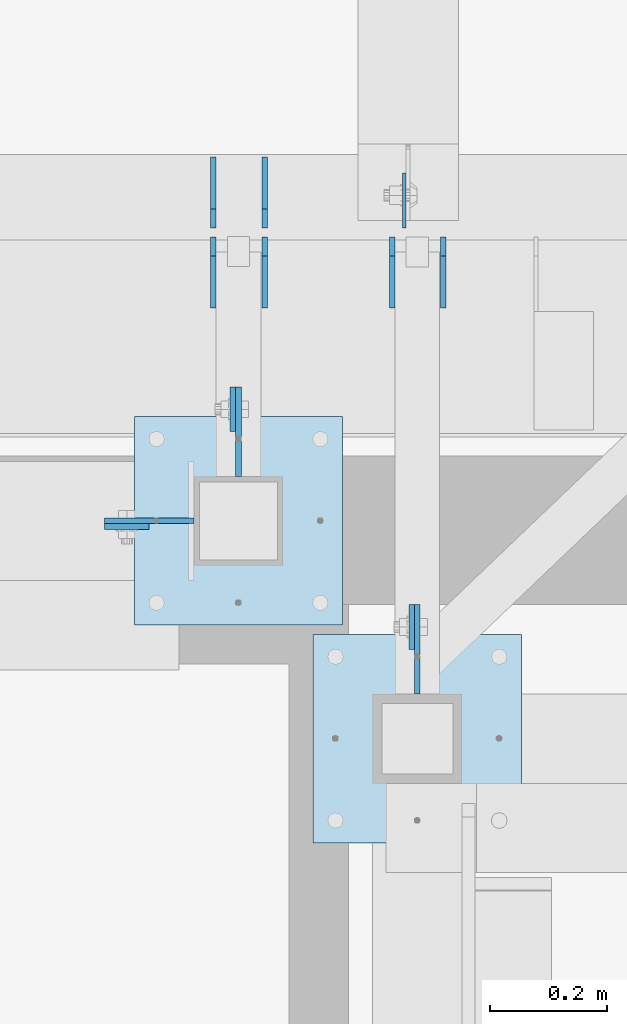
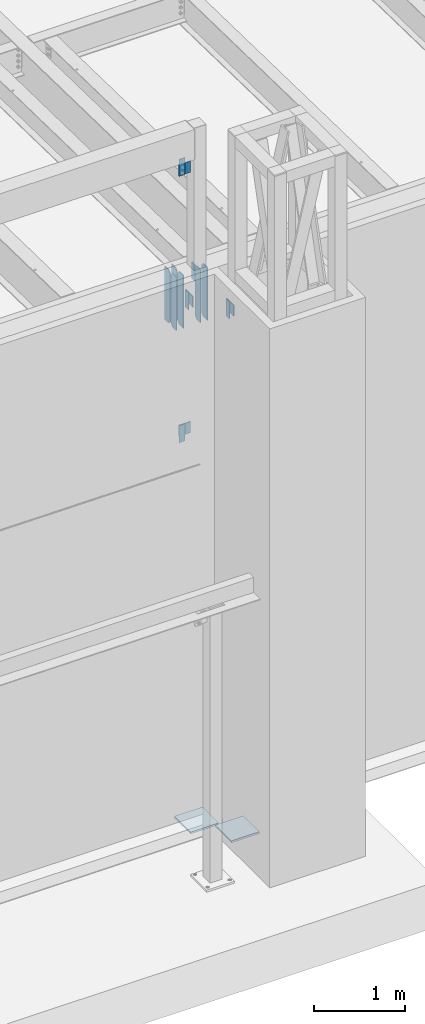
# One storey, part 1483 of 1763: 17 plates, 7 elements without a shape of their own.
"""IFC2X3 building model written with IfcOpenShell, lengths in millimetres."""

import ifcopenshell
import ifcopenshell.guid

model = None  # the IFC model being written
_history = None  # IfcOwnerHistory: only IFC2X3 demands one
_inside = {}  # id of a spatial element -> (the spatial element, [elements in it])
_under = {}  # id of a project, library or spatial element -> (it, [spatial elements below it])
_declared = {}  # id of a project -> (the project, [libraries it declares])
_typed = {}  # id of a type object -> (the type object, [elements of that type])
_made_of = {}  # id of a material, layer set ... -> (it, [elements and type objects made of it])


def new_model(schema):
    """Start an empty IFC model of exactly this schema.

    Asked for "IFC4X3", IfcOpenShell would pick the latest addendum, in which some entities
    have other attributes; the version numbers below select the first issue.
    IFC2X3 requires an IfcOwnerHistory on every rooted entity: one is made here for all.
    """
    global model, _history
    if schema == "IFC4X3":
        model = ifcopenshell.file(schema_version=(4, 3, 0, 0))
    else:
        model = ifcopenshell.file(schema=schema)
    _inside.clear()
    _under.clear()
    _declared.clear()
    _typed.clear()
    _made_of.clear()
    _history = None
    if model.schema == "IFC2X3":
        org = make("IfcOrganization", Name="unknown")
        user = make(
            "IfcPersonAndOrganization",
            ThePerson=make("IfcPerson", FamilyName="unknown"),
            TheOrganization=org,
        )
        app = make(
            "IfcApplication",
            ApplicationDeveloper=org,
            Version="unknown",
            ApplicationFullName="unknown",
            ApplicationIdentifier="unknown",
        )
        _history = make(
            "IfcOwnerHistory",
            OwningUser=user,
            OwningApplication=app,
            ChangeAction="ADDED",
            CreationDate=0,
        )
    return model


def make(cls, **values):
    """One entity of the class cls with the attributes given. An attribute that is None is left unset."""
    return model.create_entity(
        cls, **{name: value for name, value in values.items() if value is not None}
    )


def rooted(cls, **values):
    """An entity with a GlobalId (a new one), such as an element, a storey or a relation."""
    return make(cls, GlobalId=ifcopenshell.guid.new(), OwnerHistory=_history, **values)


def si_unit(unit_type, name, prefix=None):
    """IfcSIUnit, for example si_unit("LENGTHUNIT", "METRE", prefix="MILLI")."""
    return make("IfcSIUnit", UnitType=unit_type, Prefix=prefix, Name=name)


def assignment(units):
    """IfcUnitAssignment: the units of a project."""
    return None if units is None else make("IfcUnitAssignment", Units=units)


def point(xyz):
    """IfcCartesianPoint."""
    return None if xyz is None else make("IfcCartesianPoint", Coordinates=xyz)


def direction(xyz):
    """IfcDirection."""
    return None if xyz is None else make("IfcDirection", DirectionRatios=xyz)


def frame(location, z_axis=None, x_axis=None):
    """IfcAxis2Placement3D, a coordinate frame: its origin and axes. An axis left out is left unset."""
    return make(
        "IfcAxis2Placement3D",
        Location=point(location),
        Axis=direction(z_axis),
        RefDirection=direction(x_axis),
    )


def origin_with_axes():
    """The frame at (0, 0, 0) with the z axis (0, 0, 1) and the x axis (1, 0, 0) written out."""
    return frame((0.0, 0.0, 0.0), z_axis=(0.0, 0.0, 1.0), x_axis=(1.0, 0.0, 0.0))


def place(relative_to, where):
    """IfcLocalPlacement: puts the frame where relative to a parent placement (None: the world)."""
    return make(
        "IfcLocalPlacement", PlacementRelTo=relative_to, RelativePlacement=where
    )


def context(
    kind, dimensions, precision=None, world=None, true_north=None, identifier=None
):
    """IfcGeometricRepresentationContext, for example the 3D "Model" context."""
    return make(
        "IfcGeometricRepresentationContext",
        ContextIdentifier=identifier,
        ContextType=kind,
        CoordinateSpaceDimension=dimensions,
        Precision=precision,
        WorldCoordinateSystem=world,
        TrueNorth=true_north,
    )


def subcontext(parent, identifier, kind, view, scale=None):
    """IfcGeometricRepresentationSubContext, for example "Body" below "Model"."""
    return make(
        "IfcGeometricRepresentationSubContext",
        ContextIdentifier=identifier,
        ContextType=kind,
        ParentContext=parent,
        TargetScale=scale,
        TargetView=view,
    )


def project(units=None, contexts=None):
    """IfcProject with its units and contexts."""
    return rooted(
        "IfcProject",
        Name="project",
        RepresentationContexts=contexts,
        UnitsInContext=assignment(units),
    )


def spatial(cls, under=None, at=None, **own):
    """A site, building, storey or space (cls), placed at a placement, below another one or the project."""
    s = rooted(cls, ObjectPlacement=at, **own)
    if under is not None:
        _under.setdefault(under.id(), (under, []))[1].append(s)
    return s


def faces_of(points, faces, orient=None, outer=None):
    """IfcFace entities. A face is a list of loops; a loop is a list of indices into points, from 0.

    orient and outer hold one flag for each loop. By default every Orientation is true, the
    first loop of a face is its IfcFaceOuterBound and the others are IfcFaceBound.
    """
    made = []
    for i, loops in enumerate(faces):
        bounds = []
        for j, loop in enumerate(loops):
            is_outer = j == 0 if outer is None else outer[i][j]
            bounds.append(
                make(
                    "IfcFaceOuterBound" if is_outer else "IfcFaceBound",
                    Bound=make("IfcPolyLoop", Polygon=[points[k] for k in loop]),
                    Orientation=True if orient is None else orient[i][j],
                )
            )
        made.append(make("IfcFace", Bounds=bounds))
    return made


def faceted_brep(points, faces, orient=None, outer=None, voids=None):
    """IfcFacetedBrep: a solid bounded by flat faces; with voids (closed shells), ...WithVoids."""
    shared = [point(p) for p in points]
    hull = make("IfcClosedShell", CfsFaces=faces_of(shared, faces, orient, outer))
    if voids is None:
        return make("IfcFacetedBrep", Outer=hull)
    return make(
        "IfcFacetedBrepWithVoids",
        Outer=hull,
        Voids=[
            make(cls, CfsFaces=faces_of(shared, fs, o, b)) for cls, fs, o, b in voids
        ],
    )


def shape(context_of_items, identifier, shape_type, items):
    """IfcShapeRepresentation: the items that make up one representation, for example the "Body"."""
    return make(
        "IfcShapeRepresentation",
        ContextOfItems=context_of_items,
        RepresentationIdentifier=identifier,
        RepresentationType=shape_type,
        Items=items,
    )


def material(Name=None, Category=None):
    """IfcMaterial."""
    return make("IfcMaterial", Name=Name, Category=Category)


def made_of(thing, what):
    """Note that an element or type object is made of a material, layer set ...; save() writes the relation."""
    if what is not None:
        _made_of.setdefault(what.id(), (what, []))[1].append(thing)
    return thing


def type_object(cls, material=None, **own):
    """A type object (cls), such as IfcWallType, which elements share."""
    return made_of(rooted(cls, **own), material)


def element(
    cls,
    number,
    at=None,
    inside=None,
    cuts=None,
    type_object=None,
    material=None,
    context=None,
    identifier="Body",
    shape_type=None,
    held_by="IfcProductDefinitionShape",
    body=None,
    shapes=None,
    **own,
):
    """One element of the class cls, such as IfcWall. Its Tag is "e" and its number.

    at: its placement. inside: the storey or other place that contains it. cuts: it is an
    opening in that element (IfcRelVoidsElement). A single representation is given by context,
    identifier, shape_type and body (its items); several are given by shapes. held_by: the class
    of the entity that holds the representations. save() writes the other relations.
    """
    e = rooted(cls, Tag="e%d" % number, ObjectPlacement=at, **own)
    if body is not None:
        shapes = [shape(context, identifier, shape_type, body)]
    if shapes is not None:
        e.Representation = make(held_by, Representations=shapes)
    if inside is not None:
        _inside.setdefault(inside.id(), (inside, []))[1].append(e)
    if cuts is not None:
        rooted(
            "IfcRelVoidsElement", RelatingBuildingElement=cuts, RelatedOpeningElement=e
        )
    if type_object is not None:
        _typed.setdefault(type_object.id(), (type_object, []))[1].append(e)
    return made_of(e, material)


def aggregate(whole, parts):
    """IfcRelAggregates: a whole, such as a stair, and the parts it consists of."""
    return rooted("IfcRelAggregates", RelatingObject=whole, RelatedObjects=parts)


def save(model, path):
    """Write the relations noted so far, then the file.

    IfcRelAggregates (storeys below a building ...), IfcRelContainedInSpatialStructure (elements
    in a storey), IfcRelDefinesByType, IfcRelAssociatesMaterial and IfcRelDeclares: one each for
    every whole, place, type object, material and project.
    """
    for whole, parts in _under.values():
        aggregate(whole, parts)
    for where, things in _inside.values():
        rooted(
            "IfcRelContainedInSpatialStructure",
            RelatedElements=things,
            RelatingStructure=where,
        )
    for kind, things in _typed.values():
        rooted("IfcRelDefinesByType", RelatedObjects=things, RelatingType=kind)
    for what, things in _made_of.values():
        rooted("IfcRelAssociatesMaterial", RelatedObjects=things, RelatingMaterial=what)
    for by, libraries in _declared.values():
        rooted("IfcRelDeclares", RelatingContext=by, RelatedDefinitions=libraries)
    model.write(path)


model = new_model("IFC2X3")

# Units and contexts
model_context = context("Model", 3, precision=1e-05, world=origin_with_axes())
body_context = subcontext(model_context, "Body", "Model", "MODEL_VIEW")
ifc_project = project(units=[si_unit("LENGTHUNIT", "METRE", prefix="MILLI"), si_unit("AREAUNIT", "SQUARE_METRE"), si_unit("VOLUMEUNIT", "CUBIC_METRE"), si_unit("MASSUNIT", "GRAM", prefix="KILO"), si_unit("TIMEUNIT", "SECOND"), si_unit("PLANEANGLEUNIT", "RADIAN"), si_unit("SOLIDANGLEUNIT", "STERADIAN"), si_unit("THERMODYNAMICTEMPERATUREUNIT", "DEGREE_CELSIUS"), si_unit("LUMINOUSINTENSITYUNIT", "LUMEN")], contexts=[model_context])

# Site, building, storey
site_placement = place(None, origin_with_axes())
site = spatial("IfcSite", under=ifc_project, at=site_placement, CompositionType="ELEMENT")
building_placement = place(site_placement, origin_with_axes())
building = spatial("IfcBuilding", under=site, at=building_placement, Name="Undefined", CompositionType="ELEMENT")
storey_placement = place(building_placement, origin_with_axes())
storey = spatial("IfcBuildingStorey", under=building, at=storey_placement, Name="Undefined", CompositionType="ELEMENT", Elevation=0.0)

# Assembly, plate
assembly_1_placement = place(storey_placement, origin_with_axes())
assembly_1 = element("IfcElementAssembly", 1, at=assembly_1_placement, inside=storey, Name="BEAM", AssemblyPlace="NOTDEFINED", PredefinedType="RIGID_FRAME")
ifc_material = material(Name="STEEL/A36")
plate_type_1 = type_object("IfcPlateType", PredefinedType="NOTDEFINED")
plate_1_placement = place(assembly_1_placement, frame((-42097.1806100001, -14217.6514913088, 14058.9), z_axis=(0.0, 0.0, -1.0), x_axis=(-1.0, 0.0, 0.0)))
plate_1 = element("IfcPlate", 2, at=plate_1_placement, type_object=plate_type_1, material=ifc_material, Name="PLATE", context=body_context, shape_type="Brep", body=[
    faceted_brep([(0.0, -4.76249999999982, 0.0), (-2.83762346953154e-10, -4.7624999996915, 228.600006103516), (-2.83762346953154e-10, 4.76250000028813, 228.600006103517), (0.0, 4.76249999999982, 0.0), (76.1999969480166, -4.76249999961874, 228.600006103516), (76.1999969480166, 4.76250000036089, 228.600006103517), (76.1999969482931, -4.76249999991705, 0.0), (76.1999969482931, 4.76250000006257, 1.81898940354586e-12)], [[[0, 1, 2, 3]], [[1, 4, 5, 2]], [[4, 6, 7, 5]], [[6, 0, 3, 7]], [[5, 7, 3, 2]], [[6, 4, 1, 0]]]),
])
aggregate(assembly_1, [plate_1])

assembly_2_placement = place(storey_placement, origin_with_axes())
assembly_2 = element("IfcElementAssembly", 3, at=assembly_2_placement, inside=storey, Name="BEAM", AssemblyPlace="NOTDEFINED", PredefinedType="RIGID_FRAME")
plate_2_placement = place(assembly_2_placement, frame((-41954.3050625592, -14055.7264648314, 11858.625), z_axis=(0.0, 0.0, 1.0), x_axis=(0.0, 1.0, 0.0)))
plate_2 = element("IfcPlate", 4, at=plate_2_placement, type_object=plate_type_1, material=ifc_material, Name="PLATE", context=body_context, shape_type="Brep", body=[
    faceted_brep([(0.0, -4.76249999999982, 0.0), (-2.83762346953154e-10, -4.7624999996915, 228.600006103516), (-2.83762346953154e-10, 4.76250000028813, 228.600006103517), (0.0, 4.76249999999982, 0.0), (76.1999969480166, -4.76249999961874, 228.600006103516), (76.1999969480166, 4.76250000036089, 228.600006103517), (76.1999969482931, -4.76249999991705, 0.0), (76.1999969482931, 4.76250000006257, 1.81898940354586e-12)], [[[0, 1, 2, 3]], [[1, 4, 5, 2]], [[4, 6, 7, 5]], [[6, 0, 3, 7]], [[5, 7, 3, 2]], [[6, 4, 1, 0]]]),
])
aggregate(assembly_2, [plate_2])

assembly_3_placement = place(storey_placement, origin_with_axes())
assembly_3 = element("IfcElementAssembly", 5, at=assembly_3_placement, inside=storey, Name="BEAM", AssemblyPlace="NOTDEFINED", PredefinedType="RIGID_FRAME")
plate_3_placement = place(assembly_3_placement, frame((-42097.1802681081, -14217.6514930879, 10248.9), z_axis=(0.0, 0.0, 1.0), x_axis=(-1.0, 0.0, 0.0)))
plate_3 = element("IfcPlate", 6, at=plate_3_placement, type_object=plate_type_1, material=ifc_material, Name="PLATE", context=body_context, shape_type="Brep", body=[
    faceted_brep([(0.0, -4.76249999999982, 0.0), (-2.83762346953154e-10, -4.7624999996915, 228.600006103516), (-2.83762346953154e-10, 4.76250000028813, 228.600006103517), (0.0, 4.76249999999982, 0.0), (76.1999969480166, -4.76249999961874, 228.600006103516), (76.1999969480166, 4.76250000036089, 228.600006103517), (76.1999969482931, -4.76249999991705, 0.0), (76.1999969482931, 4.76250000006257, 1.81898940354586e-12)], [[[0, 1, 2, 3]], [[1, 4, 5, 2]], [[4, 6, 7, 5]], [[6, 0, 3, 7]], [[5, 7, 3, 2]], [[6, 4, 1, 0]]]),
])
aggregate(assembly_3, [plate_3])

assembly_4_placement = place(storey_placement, origin_with_axes())
assembly_4 = element("IfcElementAssembly", 7, at=assembly_4_placement, inside=storey, Name="BEAM", AssemblyPlace="NOTDEFINED", PredefinedType="RIGID_FRAME")
plate_4_placement = place(assembly_4_placement, frame((-41649.0884976177, -14427.1305908079, 11858.625), z_axis=(0.0, 0.0, 1.0), x_axis=(0.0, 1.0, 0.0)))
plate_4 = element("IfcPlate", 8, at=plate_4_placement, type_object=plate_type_1, material=ifc_material, Name="PLATE", context=body_context, shape_type="Brep", body=[
    faceted_brep([(0.0, -4.76249999999982, 0.0), (-2.83762346953154e-10, -4.7624999996915, 228.600006103516), (-2.83762346953154e-10, 4.76250000028813, 228.600006103517), (0.0, 4.76249999999982, 0.0), (76.1999969480166, -4.76249999961874, 228.600006103516), (76.1999969480166, 4.76250000036089, 228.600006103517), (76.1999969482931, -4.76249999991705, 0.0), (76.1999969482931, 4.76250000006257, 1.81898940354586e-12)], [[[0, 1, 2, 3]], [[1, 4, 5, 2]], [[4, 6, 7, 5]], [[6, 0, 3, 7]], [[5, 7, 3, 2]], [[6, 4, 1, 0]]]),
])
aggregate(assembly_4, [plate_4])

# Assembly, plates
assembly_5_placement = place(storey_placement, origin_with_axes())
assembly_5 = element("IfcElementAssembly", 9, at=assembly_5_placement, inside=storey, Name="BEAM", AssemblyPlace="NOTDEFINED", PredefinedType="RIGID_FRAME")
plate_type_2 = type_object("IfcPlateType", PredefinedType="NOTDEFINED")
plate_5_placement = place(assembly_5_placement, frame((-41900.330256172, -13844.5873186171, 11463.3375), z_axis=(0.0, 0.0, 1.0), x_axis=(0.0, 1.0, 0.0)))
plate_5 = element("IfcPlate", 10, at=plate_5_placement, type_object=plate_type_2, material=ifc_material, Name="PLATE", context=body_context, shape_type="Brep", body=[
    faceted_brep([(0.0, -4.76249999999982, 0.0), (0.0, -4.76249999999709, 714.375), (0.0, 4.76249999999709, 714.375), (0.0, 4.76249999999982, 0.0), (88.9000015258789, -4.76249999999709, 714.375), (88.9000015258789, 4.76249999999709, 714.375), (120.650001525879, -4.76249999999709, 682.625), (120.650001525879, 4.76249999999709, 682.625), (120.650001525879, -4.76249999999709, 31.75), (120.650001525879, 4.76249999999709, 31.75), (88.9000015258789, -4.76249999999709, 0.0), (88.9000015258789, 4.76249999999709, 0.0)], [[[0, 1, 2, 3]], [[1, 4, 5, 2]], [[4, 6, 7, 5]], [[6, 8, 9, 7]], [[8, 10, 11, 9]], [[10, 0, 3, 11]], [[5, 7, 9, 11, 3, 2]], [[10, 8, 6, 4, 1, 0]]]),
])
plate_6_placement = place(assembly_5_placement, frame((-41900.330256172, -13708.0623186171, 11463.3375), z_axis=(0.0, 0.0, 1.0), x_axis=(0.0, 1.0, 0.0)))
plate_6 = element("IfcPlate", 11, at=plate_6_placement, type_object=plate_type_2, material=ifc_material, Name="PLATE", context=body_context, shape_type="Brep", body=[
    faceted_brep([(0.0, -4.76250000000073, 31.75), (0.0, -4.76249999999709, 682.625), (0.0, 4.76249999999709, 682.625), (0.0, 4.76250000000073, 31.75), (31.75, -4.76249999999709, 714.375), (31.75, 4.76249999999709, 714.375), (120.650001525879, -4.76249999999709, 714.375), (120.650001525879, 4.76249999999709, 714.375), (120.650001525879, -4.76249999999709, 0.0), (120.650001525879, 4.76249999999709, 0.0), (31.75, -4.76250000000073, 0.0), (31.75, 4.76250000000073, 0.0)], [[[0, 1, 2, 3]], [[1, 4, 5, 2]], [[4, 6, 7, 5]], [[6, 8, 9, 7]], [[8, 10, 11, 9]], [[10, 0, 3, 11]], [[5, 7, 9, 11, 3, 2]], [[10, 8, 6, 4, 1, 0]]]),
])
plate_7_placement = place(assembly_5_placement, frame((-41987.642756172, -13844.5873186171, 11463.3375), z_axis=(0.0, 0.0, 1.0), x_axis=(0.0, 1.0, 0.0)))
plate_7 = element("IfcPlate", 12, at=plate_7_placement, type_object=plate_type_2, material=ifc_material, Name="PLATE", context=body_context, shape_type="Brep", body=[
    faceted_brep([(0.0, -4.76249999999982, 0.0), (0.0, -4.76249999999709, 714.375), (0.0, 4.76249999999709, 714.375), (0.0, 4.76249999999982, 0.0), (88.9000015258789, -4.76249999999709, 714.375), (88.9000015258789, 4.76249999999709, 714.375), (120.650001525879, -4.76249999999709, 682.625), (120.650001525879, 4.76249999999709, 682.625), (120.650001525879, -4.76249999999709, 31.75), (120.650001525879, 4.76249999999709, 31.75), (88.9000015258789, -4.76249999999709, 0.0), (88.9000015258789, 4.76249999999709, 0.0)], [[[0, 1, 2, 3]], [[1, 4, 5, 2]], [[4, 6, 7, 5]], [[6, 8, 9, 7]], [[8, 10, 11, 9]], [[10, 0, 3, 11]], [[5, 7, 9, 11, 3, 2]], [[10, 8, 6, 4, 1, 0]]]),
])
plate_8_placement = place(assembly_5_placement, frame((-41987.642756172, -13708.0623186171, 11463.3375), z_axis=(0.0, 0.0, 1.0), x_axis=(0.0, 1.0, 0.0)))
plate_8 = element("IfcPlate", 13, at=plate_8_placement, type_object=plate_type_2, material=ifc_material, Name="PLATE", context=body_context, shape_type="Brep", body=[
    faceted_brep([(0.0, -4.76250000000073, 31.75), (0.0, -4.76249999999709, 682.625), (0.0, 4.76249999999709, 682.625), (0.0, 4.76250000000073, 31.75), (31.75, -4.76249999999709, 714.375), (31.75, 4.76249999999709, 714.375), (120.650001525879, -4.76249999999709, 714.375), (120.650001525879, 4.76249999999709, 714.375), (120.650001525879, -4.76249999999709, 0.0), (120.650001525879, 4.76249999999709, 0.0), (31.75, -4.76250000000073, 0.0), (31.75, 4.76250000000073, 0.0)], [[[0, 1, 2, 3]], [[1, 4, 5, 2]], [[4, 6, 7, 5]], [[6, 8, 9, 7]], [[8, 10, 11, 9]], [[10, 0, 3, 11]], [[5, 7, 9, 11, 3, 2]], [[10, 8, 6, 4, 1, 0]]]),
])
plate_9_placement = place(assembly_5_placement, frame((-41595.1134959181, -13844.5873186171, 11463.3375), z_axis=(0.0, 0.0, 1.0), x_axis=(0.0, 1.0, 0.0)))
plate_9 = element("IfcPlate", 14, at=plate_9_placement, type_object=plate_type_2, material=ifc_material, Name="PLATE", context=body_context, shape_type="Brep", body=[
    faceted_brep([(0.0, -4.76249999999982, 0.0), (0.0, -4.76249999999709, 714.375), (0.0, 4.76249999999709, 714.375), (0.0, 4.76249999999982, 0.0), (88.9000015258789, -4.76249999999709, 714.375), (88.9000015258789, 4.76249999999709, 714.375), (120.650001525879, -4.76249999999709, 682.625), (120.650001525879, 4.76249999999709, 682.625), (120.650001525879, -4.76249999999709, 31.75), (120.650001525879, 4.76249999999709, 31.75), (88.9000015258789, -4.76249999999709, 0.0), (88.9000015258789, 4.76249999999709, 0.0)], [[[0, 1, 2, 3]], [[1, 4, 5, 2]], [[4, 6, 7, 5]], [[6, 8, 9, 7]], [[8, 10, 11, 9]], [[10, 0, 3, 11]], [[5, 7, 9, 11, 3, 2]], [[10, 8, 6, 4, 1, 0]]]),
])
plate_10_placement = place(assembly_5_placement, frame((-41682.4259959181, -13844.5873186171, 11463.3375), z_axis=(0.0, 0.0, 1.0), x_axis=(0.0, 1.0, 0.0)))
plate_10 = element("IfcPlate", 15, at=plate_10_placement, type_object=plate_type_2, material=ifc_material, Name="PLATE", context=body_context, shape_type="Brep", body=[
    faceted_brep([(0.0, -4.76249999999982, 0.0), (0.0, -4.76249999999709, 714.375), (0.0, 4.76249999999709, 714.375), (0.0, 4.76249999999982, 0.0), (88.9000015258789, -4.76249999999709, 714.375), (88.9000015258789, 4.76249999999709, 714.375), (120.650001525879, -4.76249999999709, 682.625), (120.650001525879, 4.76249999999709, 682.625), (120.650001525879, -4.76249999999709, 31.75), (120.650001525879, 4.76249999999709, 31.75), (88.9000015258789, -4.76249999999709, 0.0), (88.9000015258789, 4.76249999999709, 0.0)], [[[0, 1, 2, 3]], [[1, 4, 5, 2]], [[4, 6, 7, 5]], [[6, 8, 9, 7]], [[8, 10, 11, 9]], [[10, 0, 3, 11]], [[5, 7, 9, 11, 3, 2]], [[10, 8, 6, 4, 1, 0]]]),
])

assembly_6_placement = place(storey_placement, origin_with_axes())
assembly_6 = element("IfcElementAssembly", 16, at=assembly_6_placement, inside=storey, Name="COLUMN", AssemblyPlace="NOTDEFINED", PredefinedType="RIGID_FRAME")
plate_type_3 = type_object("IfcPlateType", PredefinedType="NOTDEFINED")
plate_11_placement = place(assembly_6_placement, frame((-42173.3806069008, -14208.126492046, 13830.2999938965), z_axis=(0.0, 0.0, 1.0), x_axis=(1.0, 0.0, 0.0)))
plate_11 = element("IfcPlate", 17, at=plate_11_placement, type_object=plate_type_3, material=ifc_material, Name="PLATE", context=body_context, shape_type="Brep", body=[
    faceted_brep([(0.0, -4.76249999999982, 0.0), (-3.05175672110636e-06, -4.7625000002663, 152.399993896484), (-3.05175490211695e-06, 4.76249999972788, 152.399993896484), (0.0, 4.76249999999982, 0.0), (152.400009155272, -4.76249999975698, 152.399993896484), (152.400009155273, 4.76250000024447, 152.399993896484), (152.400009155272, -4.76249999948777, 5.45696821063757e-12), (152.400009155273, 4.76250000051368, 3.63797880709171e-12)], [[[0, 1, 2, 3]], [[1, 4, 5, 2]], [[4, 6, 7, 5]], [[6, 0, 3, 7]], [[5, 7, 3, 2]], [[6, 4, 1, 0]]]),
])
plate_12_placement = place(assembly_6_placement, frame((-41944.7800640592, -13979.5264678355, 12087.2250061035), z_axis=(0.0, 0.0, -1.0), x_axis=(0.0, -1.0, 0.0)))
plate_12 = element("IfcPlate", 18, at=plate_12_placement, type_object=plate_type_3, material=ifc_material, Name="PLATE", context=body_context, shape_type="Brep", body=[
    faceted_brep([(0.0, -4.76249999999982, 0.0), (-3.05175672110636e-06, -4.7625000002663, 152.399993896484), (-3.05175490211695e-06, 4.76249999972788, 152.399993896484), (0.0, 4.76249999999982, 0.0), (152.400009155272, -4.76249999975698, 152.399993896484), (152.400009155273, 4.76250000024447, 152.399993896484), (152.400009155272, -4.76249999948777, 5.45696821063757e-12), (152.400009155273, 4.76250000051368, 3.63797880709171e-12)], [[[0, 1, 2, 3]], [[1, 4, 5, 2]], [[4, 6, 7, 5]], [[6, 0, 3, 7]], [[5, 7, 3, 2]], [[6, 4, 1, 0]]]),
])
plate_13_placement = place(assembly_6_placement, frame((-42173.3802651039, -14208.1264945876, 10477.5000061035), z_axis=(0.0, 0.0, -1.0), x_axis=(1.0, 0.0, 0.0)))
plate_13 = element("IfcPlate", 19, at=plate_13_placement, type_object=plate_type_3, material=ifc_material, Name="PLATE", context=body_context, shape_type="Brep", body=[
    faceted_brep([(0.0, -4.76249999999982, 0.0), (-3.05175672110636e-06, -4.7625000002663, 152.399993896484), (-3.05175490211695e-06, 4.76249999972788, 152.399993896484), (0.0, 4.76249999999982, 0.0), (152.400009155272, -4.76249999975698, 152.399993896484), (152.400009155273, 4.76250000024447, 152.399993896484), (152.400009155272, -4.76249999948777, 5.45696821063757e-12), (152.400009155273, 4.76250000051368, 3.63797880709171e-12)], [[[0, 1, 2, 3]], [[1, 4, 5, 2]], [[4, 6, 7, 5]], [[6, 0, 3, 7]], [[5, 7, 3, 2]], [[6, 4, 1, 0]]]),
])

# Assembly, plate
assembly_7_placement = place(storey_placement, origin_with_axes())
assembly_7 = element("IfcElementAssembly", 20, at=assembly_7_placement, inside=storey, Name="FRAME", AssemblyPlace="NOTDEFINED", PredefinedType="RIGID_FRAME")
plate_14_placement = place(assembly_7_placement, frame((-41639.5634991177, -14350.9305938121, 12087.2250061035), z_axis=(0.0, 0.0, -1.0), x_axis=(0.0, -1.0, 0.0)))
plate_14 = element("IfcPlate", 21, at=plate_14_placement, type_object=plate_type_3, material=ifc_material, Name="PLATE", context=body_context, shape_type="Brep", body=[
    faceted_brep([(0.0, -4.76249999999982, 0.0), (-3.05175672110636e-06, -4.7625000002663, 152.399993896484), (-3.05175490211695e-06, 4.76249999972788, 152.399993896484), (0.0, 4.76249999999982, 0.0), (152.400009155272, -4.76249999975698, 152.399993896484), (152.400009155273, 4.76250000024447, 152.399993896484), (152.400009155272, -4.76249999948777, 5.45696821063757e-12), (152.400009155273, 4.76250000051368, 3.63797880709171e-12)], [[[0, 1, 2, 3]], [[1, 4, 5, 2]], [[4, 6, 7, 5]], [[6, 0, 3, 7]], [[5, 7, 3, 2]], [[6, 4, 1, 0]]]),
])

# Plate
plate_type_4 = type_object("IfcPlateType", PredefinedType="NOTDEFINED")
plate_15_placement = place(assembly_6_placement, frame((-42122.580256172, -14030.3264769908, 5080.0), z_axis=(1.0, 0.0, 0.0), x_axis=(0.0, -1.0, 0.0)))
plate_15 = element("IfcPlate", 22, at=plate_15_placement, type_object=plate_type_4, material=ifc_material, Name="PLATE", context=body_context, shape_type="Brep", body=[
    faceted_brep([(0.0, -12.6999999999971, -1.81898940354586e-12), (0.0, -12.6999999999998, 355.600006103516), (0.0, 12.6999999999998, 355.600006103516), (0.0, 12.6999999999971, -1.81898940354586e-12), (355.600006103516, -12.6999999999998, 355.600006103516), (355.600006103516, 12.6999999999998, 355.600006103516), (355.600006103516, -12.6999999999998, 0.0), (355.600006103516, 12.6999999999998, 0.0)], [[[0, 1, 2, 3]], [[1, 4, 5, 2]], [[4, 6, 7, 5]], [[6, 0, 3, 7]], [[5, 7, 3, 2]], [[6, 4, 1, 0]]]),
])

aggregate(assembly_6, [plate_15, plate_11, plate_12, plate_13])

plate_16_placement = place(assembly_7_placement, frame((-41817.3634959181, -14401.7306029674, 5079.99999999999), z_axis=(1.0, 0.0, 0.0), x_axis=(0.0, -1.0, 0.0)))
plate_16 = element("IfcPlate", 23, at=plate_16_placement, type_object=plate_type_4, material=ifc_material, Name="PLATE", context=body_context, shape_type="Brep", body=[
    faceted_brep([(0.0, -12.6999999999971, -1.81898940354586e-12), (0.0, -12.6999999999998, 355.600006103516), (0.0, 12.6999999999998, 355.600006103516), (0.0, 12.6999999999971, -1.81898940354586e-12), (355.600006103516, -12.6999999999998, 355.600006103516), (355.600006103516, 12.6999999999998, 355.600006103516), (355.600006103516, -12.6999999999998, 0.0), (355.600006103516, 12.6999999999998, 0.0)], [[[0, 1, 2, 3]], [[1, 4, 5, 2]], [[4, 6, 7, 5]], [[6, 0, 3, 7]], [[5, 7, 3, 2]], [[6, 4, 1, 0]]]),
])

aggregate(assembly_7, [plate_14, plate_16])

plate_type_5 = type_object("IfcPlateType", PredefinedType="NOTDEFINED")
plate_17_placement = place(assembly_5_placement, frame((-41661.7884959181, -13708.0623186171, 12141.4823251617), z_axis=(0.0, 1.0, 0.0), x_axis=(0.0, 0.0, -1.0)))
plate_17 = element("IfcPlate", 24, at=plate_17_placement, type_object=plate_type_5, material=ifc_material, Name="PLATE", context=body_context, shape_type="Brep", body=[
    faceted_brep([(1.81898940354586e-12, -3.17500000000291, 0.0), (0.0, -3.17499999999927, 93.6624984741211), (0.0, 3.17499999999927, 93.6624984741211), (-1.81898940354586e-12, 3.17499999997381, 0.0), (228.600006103516, -3.17499999999927, 93.6624984741211), (228.600006103516, 3.17499999999927, 93.6624984741211), (228.600006103516, -3.17500000001019, -7.27595761418343e-12), (228.600006103516, 3.17499999999563, -7.27595761418343e-12)], [[[0, 1, 2, 3]], [[1, 4, 5, 2]], [[4, 6, 7, 5]], [[6, 0, 3, 7]], [[5, 7, 3, 2]], [[6, 4, 1, 0]]]),
])

aggregate(assembly_5, [plate_5, plate_6, plate_7, plate_8, plate_9, plate_10, plate_17])

save(model, "model.ifc")
